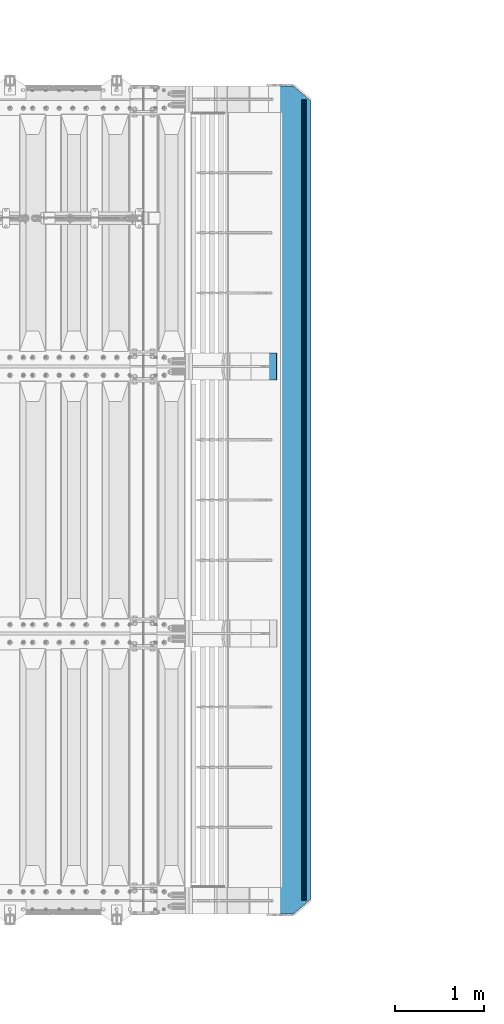
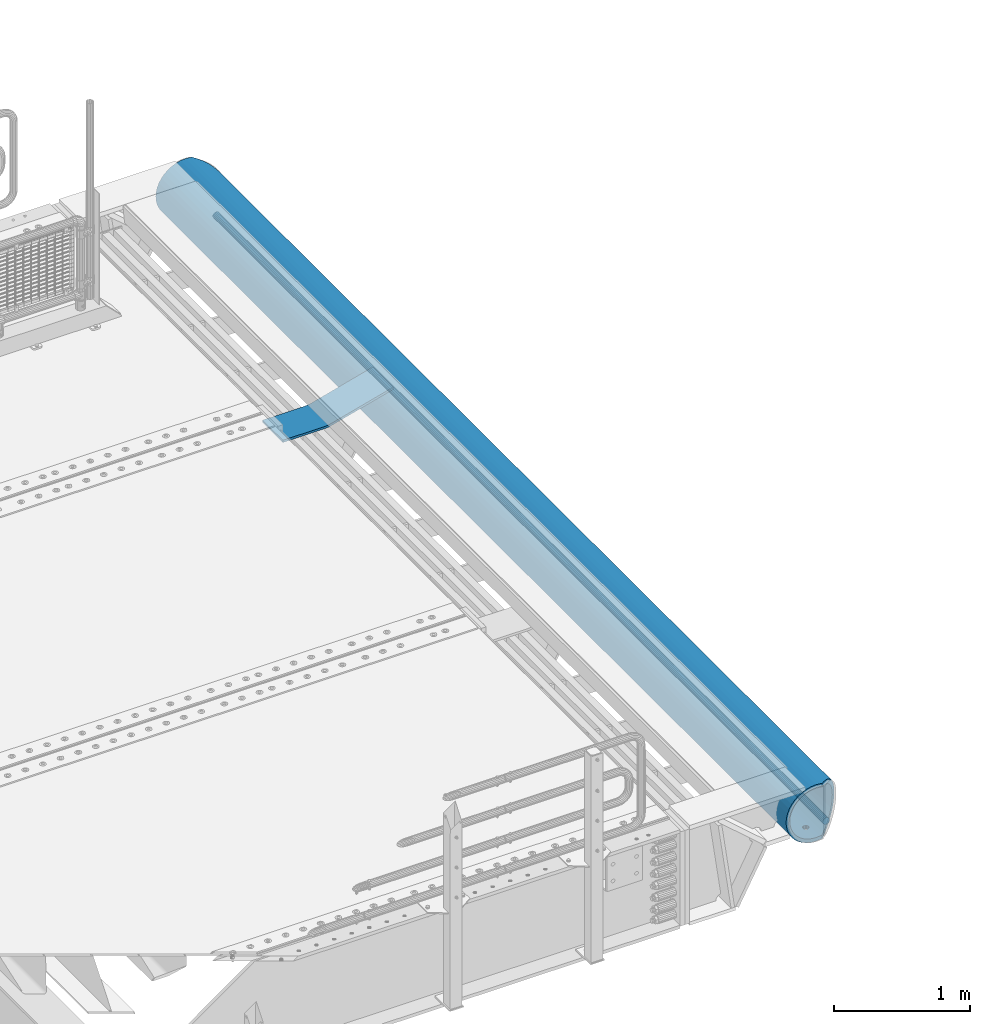
# One storey, part 133 of 247: 3 beams.
"""IFC2X3 building model written with IfcOpenShell, lengths in millimetres."""

from ifc_helpers import new_model, si_unit, frame, origin_with_axes, place, context, subcontext, project, spatial, faceted_brep, material, type_object, element, save


model = new_model("IFC2X3")

# Units and contexts
model_context = context("Model", 3, precision=1e-05, world=origin_with_axes())
body_context = subcontext(model_context, "Body", "Model", "MODEL_VIEW")
ifc_project = project(units=[si_unit("LENGTHUNIT", "METRE", prefix="MILLI"), si_unit("AREAUNIT", "SQUARE_METRE"), si_unit("VOLUMEUNIT", "CUBIC_METRE"), si_unit("MASSUNIT", "GRAM", prefix="KILO"), si_unit("TIMEUNIT", "SECOND"), si_unit("PLANEANGLEUNIT", "RADIAN"), si_unit("SOLIDANGLEUNIT", "STERADIAN"), si_unit("THERMODYNAMICTEMPERATUREUNIT", "DEGREE_CELSIUS"), si_unit("LUMINOUSINTENSITYUNIT", "LUMEN")], contexts=[model_context])

# Site, building, storey
site_placement = place(None, origin_with_axes())
site = spatial("IfcSite", under=ifc_project, at=site_placement, CompositionType="ELEMENT")
building_placement = place(site_placement, origin_with_axes())
building = spatial("IfcBuilding", under=site, at=building_placement, Name="Standard", CompositionType="ELEMENT")
storey_placement = place(building_placement, origin_with_axes())
storey = spatial("IfcBuildingStorey", under=building, at=storey_placement, Name="Undefined", CompositionType="ELEMENT", Elevation=0.0)

# Beams
ifc_material = material(Name="STEEL/S355N")
beam_type_1 = type_object("IfcBeamType", PredefinedType="NOTDEFINED")
beam_1_placement = place(storey_placement, frame((16896.9988298906, 6000.0, -169.999999999995), z_axis=(0.0, -0.999999999999548, -9.5100000000016e-07), x_axis=(1.0, 0.0, 0.0)))
element("IfcBeam", 1, at=beam_1_placement, inside=storey, type_object=beam_type_1, material=ifc_material, context=body_context, shape_type="Brep", body=[
    faceted_brep([(0.0, 10.0, -150.0), (0.0, 10.0, 150.0), (356.495387467741, 10.0, 150.0), (356.495387467749, 9.99999999999901, -150.0), (0.0, -10.0, 150.0), (0.0, -10.0, -150.0), (356.495387467741, -10.0, -150.0), (356.495387467741, -10.0, 150.0), (382.770279632416, 11.7334369044542, 150.0), (382.770279632416, 11.7334369044542, -150.0), (385.397768848896, -8.09321940509935, -150.0), (385.397768848896, -8.09321940509935, 150.0), (413.799145684919, -2.40593045895554, -150.0), (413.799145684919, -2.40593045895554, 150.0), (408.589713119687, 16.9036995827646, 150.0), (408.589713119891, 16.9036995827009, -150.0), (939.000000000015, 160.0, 150.0), (939.000000000015, 160.0, -150.0), (944.209432565229, 140.69036995827, 150.0), (944.209432565229, 140.69036995827, -150.0)], [[[0, 1, 2, 3]], [[4, 5, 6, 7]], [[5, 4, 1, 0]], [[3, 2, 8, 9]], [[7, 6, 10, 11]], [[10, 12, 13, 11]], [[8, 14, 15, 9]], [[15, 14, 16, 17]], [[14, 8, 2, 1, 4, 7, 11, 13, 18, 16]], [[13, 12, 19, 18]], [[12, 10, 6, 5, 0, 3, 9, 15, 17, 19]], [[18, 19, 17, 16]]]),
])
beam_type_2 = type_object("IfcBeamType", PredefinedType="NOTDEFINED")
beam_2_placement = place(storey_placement, frame((17972.9988298906, 9150.0, -254.000000000001), z_axis=(0.0, 0.0, 1.0), x_axis=(0.0, -0.999999999999548, -9.5100000000016e-07)))
element("IfcBeam", 2, at=beam_2_placement, inside=storey, type_object=beam_type_2, material=ifc_material, context=body_context, shape_type="Brep", body=[
    faceted_brep([(6132.32233047034, -17.6739734137809, -220.609028125962), (6132.32233047034, -17.6739734137809, -252.609028125962), (6126.90301168722, -9.56338969324497, -253.247344908112), (6126.90301168722, -9.56338969324497, -221.247344908112), (6140.43291419087, -23.0932921968997, -220.182518487904), (6140.43291419087, -23.0932921968997, -252.182518487904), (6150.0, -24.9963038841161, -220.032748220012), (6150.0, -24.9963038841161, -252.032748220013), (6159.56708580913, -23.0932921968997, -220.182518487904), (6159.56708580913, -23.0932921968997, -252.182518487904), (6167.67766952966, -17.6739734137809, -220.609028125962), (6167.67766952966, -17.6739734137809, -252.609028125962), (6173.09698831278, -9.56338969324497, -221.247344908112), (6173.09698831278, -9.56338969324497, -253.247344908112), (6175.0, 0.0, -222.0), (6175.0, 0.0, -254.0), (6173.09698831278, 9.57078192501285, -221.246763126856), (6173.09698831278, 9.57078192501285, -253.246763126856), (6167.67766952966, 17.6813656455488, -220.608446344706), (6167.67766952966, 17.6813656455488, -252.608446344706), (6159.56708580913, 23.1006844286676, -220.181936706648), (6159.56708580913, 23.1006844286676, -252.181936706647), (6150.0, 25.0036961158839, -220.032166438756), (6150.0, 25.0036961158839, -252.032166438756), (6140.43291419087, 23.1006844286676, -220.181936706648), (6140.43291419087, 23.1006844286676, -252.181936706647), (6132.32233047034, 17.6813656455488, -220.608446344706), (6132.32233047034, 17.6813656455488, -252.608446344706), (6126.90301168722, 9.57078192501285, -221.246763126856), (6126.90301168722, 9.57078192501285, -253.246763126856), (6125.0, 0.0, -222.0), (6125.0, 0.0, -254.0), (4632.32233047034, -17.6739734137773, -220.609028125962), (4632.32233047034, -17.6739734137773, -252.609028125962), (4626.90301168722, -9.56338969324133, -253.247344908112), (4626.90301168722, -9.56338969324133, -221.247344908112), (4640.43291419087, -23.0932921968961, -220.182518487904), (4640.43291419087, -23.0932921968961, -252.182518487903), (4650.0, -24.9963038841124, -220.032748220013), (4650.0, -24.9963038841124, -252.032748220012), (4659.56708580913, -23.0932921968961, -220.182518487904), (4659.56708580913, -23.0932921968961, -252.182518487903), (4667.67766952966, -17.6739734137773, -220.609028125962), (4667.67766952966, -17.6739734137773, -252.609028125962), (4673.09698831278, -9.56338969324133, -221.247344908112), (4673.09698831278, -9.56338969324133, -253.247344908112), (4675.0, 0.0, -222.0), (4675.0, 0.0, -254.0), (4673.09698831278, 9.57078192501649, -221.246763126856), (4673.09698831278, 9.57078192501649, -253.246763126855), (4667.67766952966, 17.6813656455524, -220.608446344706), (4667.67766952966, 17.6813656455524, -252.608446344705), (4659.56708580913, 23.1006844286712, -220.181936706647), (4659.56708580913, 23.1006844286712, -252.181936706647), (4650.0, 25.0036961158876, -220.032166438756), (4650.0, 25.0036961158876, -252.032166438756), (4640.43291419087, 23.1006844286712, -220.181936706647), (4640.43291419087, 23.1006844286712, -252.181936706647), (4632.32233047034, 17.6813656455524, -220.608446344706), (4632.32233047034, 17.6813656455524, -252.608446344705), (4626.90301168722, 9.57078192501649, -221.246763126856), (4626.90301168722, 9.57078192501649, -253.246763126855), (4625.0, 0.0, -222.0), (4625.0, 0.0, -254.0), (3132.32233047034, -17.6776695296612, -220.608737235334), (3132.32233047034, -17.6776695296612, -252.608737235334), (3126.90301168722, -9.56708580912527, -253.247054017484), (3126.90301168722, -9.56708580912527, -221.247054017484), (3140.43291419087, -23.09698831278, -220.182227597276), (3140.43291419087, -23.09698831278, -252.182227597276), (3150.0, -24.9999999999964, -220.032457329385), (3150.0, -24.9999999999964, -252.032457329385), (3159.56708580913, -23.09698831278, -220.182227597276), (3159.56708580913, -23.09698831278, -252.182227597276), (3167.67766952966, -17.6776695296612, -220.608737235334), (3167.67766952966, -17.6776695296612, -252.608737235334), (3173.09698831278, -9.56708580912527, -221.247054017484), (3173.09698831278, -9.56708580912527, -253.247054017484), (3175.0, 0.0, -222.0), (3175.0, 0.0, -254.0), (3173.09698831278, 9.56708580913255, -221.247054017484), (3173.09698831278, 9.56708580913255, -253.247054017483), (3167.67766952966, 17.6776695296685, -220.608737235334), (3167.67766952966, 17.6776695296685, -252.608737235333), (3159.56708580913, 23.0969883127873, -220.182227597276), (3159.56708580913, 23.0969883127873, -252.182227597275), (3150.0, 25.0000000000036, -220.032457329384), (3150.0, 25.0000000000036, -252.032457329384), (3140.43291419087, 23.0969883127873, -220.182227597276), (3140.43291419087, 23.0969883127873, -252.182227597275), (3132.32233047034, 17.6776695296685, -220.608737235334), (3132.32233047034, 17.6776695296685, -252.608737235333), (3126.90301168722, 9.56708580913255, -221.247054017484), (3126.90301168722, 9.56708580913255, -253.247054017483), (3125.0, 0.0, -222.0), (3125.0, 0.0, -254.0), (1632.32233047034, -17.6776695296612, -220.608737235334), (1632.32233047034, -17.6776695296612, -252.608737235334), (1626.90301168722, -9.56708580912527, -253.247054017484), (1626.90301168722, -9.56708580912527, -221.247054017484), (1640.43291419087, -23.09698831278, -220.182227597276), (1640.43291419087, -23.09698831278, -252.182227597276), (1650.0, -24.9999999999964, -220.032457329385), (1650.0, -24.9999999999964, -252.032457329385), (1659.56708580913, -23.09698831278, -220.182227597276), (1659.56708580913, -23.09698831278, -252.182227597276), (1667.67766952966, -17.6776695296612, -220.608737235334), (1667.67766952966, -17.6776695296612, -252.608737235334), (1673.09698831278, -9.56708580912527, -221.247054017484), (1673.09698831278, -9.56708580912527, -253.247054017484), (1675.0, 0.0, -222.0), (1675.0, 0.0, -254.0), (1673.09698831278, 9.56708580913255, -221.247054017484), (1673.09698831278, 9.56708580913255, -253.247054017484), (1667.67766952966, 17.6776695296685, -220.608737235334), (1667.67766952966, 17.6776695296685, -252.608737235334), (1659.56708580913, 23.0969883127873, -220.182227597276), (1659.56708580913, 23.0969883127873, -252.182227597275), (1650.0, 25.0000000000036, -220.032457329384), (1650.0, 25.0000000000036, -252.032457329384), (1640.43291419087, 23.0969883127873, -220.182227597276), (1640.43291419087, 23.0969883127873, -252.182227597275), (1632.32233047034, 17.6776695296685, -220.608737235334), (1632.32233047034, 17.6776695296685, -252.608737235334), (1626.90301168722, 9.56708580913255, -221.247054017484), (1626.90301168722, 9.56708580913255, -253.247054017484), (1625.0, 0.0, -222.0), (1625.0, 0.0, -254.0), (132.322330470337, -17.6776695296612, -220.608737235334), (132.322330470337, -17.6776695296612, -252.608737235334), (126.903011687218, -9.56708580912527, -253.247054017484), (126.903011687218, -9.56708580912527, -221.247054017484), (140.432914190873, -23.09698831278, -220.182227597276), (140.432914190873, -23.09698831278, -252.182227597276), (150.0, -24.9999999999964, -220.032457329385), (150.0, -24.9999999999964, -252.032457329385), (159.567085809127, -23.09698831278, -220.182227597276), (159.567085809127, -23.09698831278, -252.182227597276), (167.677669529663, -17.6776695296612, -220.608737235334), (167.677669529663, -17.6776695296612, -252.608737235334), (173.096988312782, -9.56708580912527, -221.247054017484), (173.096988312782, -9.56708580912527, -253.247054017484), (175.0, 0.0, -222.0), (175.0, 0.0, -254.0), (173.096988312782, 9.56708580913255, -221.247054017484), (173.096988312782, 9.56708580913255, -253.247054017484), (167.677669529663, 17.6776695296685, -220.608737235333), (167.677669529663, 17.6776695296685, -252.608737235334), (159.567085809127, 23.0969883127873, -220.182227597275), (159.567085809127, 23.0969883127873, -252.182227597275), (150.0, 25.0000000000036, -220.032457329384), (150.0, 25.0000000000036, -252.032457329384), (140.432914190873, 23.0969883127873, -220.182227597275), (140.432914190873, 23.0969883127873, -252.182227597275), (132.322330470337, 17.6776695296685, -220.608737235333), (132.322330470337, 17.6776695296685, -252.608737235334), (126.903011687218, 9.56708580913255, -221.247054017484), (126.903011687218, 9.56708580913255, -253.247054017484), (125.0, 0.0, -222.0), (125.0, 0.0, -254.0), (0.0, -34.7284512389306, -219.266811612121), (0.0, -68.6017727512371, -211.134546617524), (9300.0, -68.6017727512371, -211.134546617524), (9300.0, -34.7284512389306, -219.266811612121), (0.0, -100.785890942181, -197.803448369818), (9300.0, -100.785890942181, -197.803448369818), (0.0, -130.48832600893, -179.601772751238), (9300.0, -130.48832600893, -179.601772751238), (0.0, -156.977705423415, -156.977705423414), (9300.0, -156.977705423415, -156.977705423414), (0.0, -179.601772751237, -130.488326008929), (9300.0, -179.601772751237, -130.488326008929), (0.0, -197.803448369817, -100.785890942179), (9300.0, -197.803448369817, -100.785890942179), (0.0, -211.134546617523, -68.6017727512383), (9300.0, -211.134546617523, -68.6017727512383), (0.0, -219.26681161212, -34.7284512389313), (9300.0, -219.26681161212, -34.7284512389313), (0.0, -222.0, 0.0), (9300.0, -222.0, 0.0), (0.0, -219.26681161212, 34.7284512389313), (9300.0, -219.26681161212, 34.7284512389313), (0.0, -211.134546617523, 68.6017727512384), (9300.0, -211.134546617523, 68.6017727512384), (0.0, -197.803448369817, 100.785890942179), (9300.0, -197.803448369817, 100.785890942179), (0.0, -179.601772751237, 130.488326008929), (9300.0, -179.601772751237, 130.488326008929), (0.0, -156.977705423415, 156.977705423414), (9300.0, -156.977705423415, 156.977705423414), (0.0, -130.48832600893, 179.601772751238), (9300.0, -130.48832600893, 179.601772751238), (0.0, -100.785890942181, 197.803448369818), (9300.0, -100.785890942181, 197.803448369818), (0.0, -68.6017727512371, 211.134546617524), (9300.0, -68.6017727512371, 211.134546617524), (0.0, -34.7284512389306, 219.266811612121), (9300.0, -34.7284512389306, 219.266811612121), (0.0, 0.0, 222.0), (9300.0, 0.0, 222.0), (0.0, 34.7284512389306, 219.266811612121), (9300.0, 34.7284512389306, 219.266811612121), (9287.5916350975, 68.6017727512371, 211.134546617524), (9300.0, 54.0036961158876, 214.639234741095), (0.0, 54.0000000000036, 214.64012210001), (12.411506742721, 68.6017727512371, 211.134546617524), (9260.23513515892, 100.785890942181, 197.803448369818), (39.7680069938197, 100.785890942181, 197.803448369818), (9234.98806583553, 130.48832600893, 179.601772751238), (65.015076605634, 130.48832600893, 179.601772751238), (9212.47209376427, 156.977705423415, 156.977705423414), (87.5310489341118, 156.977705423415, 156.977705423414), (9193.24163690377, 179.601772751237, 130.488326008929), (106.761506014294, 179.601772751237, 130.488326008929), (9177.77021292417, 197.803448369817, 100.785890942179), (122.232930170643, 197.803448369817, 100.785890942179), (9166.43877963055, 211.134546617523, 68.6017727512383), (133.564363593709, 211.134546617523, 68.6017727512383), (9159.52635451748, 219.26681161212, 34.7284512389312), (140.476788785749, 219.26681161212, 34.7284512389312), (9157.20314443226, 222.0, -2.8421709430404e-14), (142.799998897508, 222.0, -2.8421709430404e-14), (9159.52635451748, 219.26681161212, -34.7284512389313), (140.476788785749, 219.26681161212, -34.7284512389313), (9166.43877963055, 211.134546617523, -68.6017727512383), (133.564363593709, 211.134546617523, -68.6017727512383), (9177.77021292417, 197.803448369817, -100.785890942179), (122.232930170643, 197.803448369817, -100.785890942179), (9193.24163690377, 179.601772751237, -130.488326008929), (106.761506014294, 179.601772751237, -130.488326008929), (9212.47209376427, 156.977705423415, -156.977705423414), (87.5310489341118, 156.977705423415, -156.977705423414), (9234.98806583553, 130.48832600893, -179.601772751238), (65.015076605634, 130.48832600893, -179.601772751238), (9260.23513515892, 100.785890942181, -197.803448369818), (39.7680069938197, 100.785890942181, -197.803448369818), (9287.5916350975, 68.6017727512371, -211.134546617524), (12.411506742721, 68.6017727512371, -211.134546617524), (0.0, 34.7284512389306, -219.266811612121), (9300.0, 34.7284512389306, -219.266811612121), (9300.0, 54.0036961158876, -214.639234741095), (0.0, 54.0000000000036, -214.64012210001), (9140.57004288257, 241.56835513897, -78.4903165712366), (9153.53483593022, 226.315657143845, -115.313586933845), (146.468307441455, 226.315657143845, -115.313586933845), (159.433100637219, 241.56835513897, -78.4903165712366), (9171.23637507805, 205.490316571235, -149.297454082288), (128.766768091398, 205.490316571235, -149.297454082288), (9193.2387896842, 179.605122421384, -179.605122421383), (106.764353233899, 179.605122421384, -179.605122421383), (9219.00030727925, 149.297454082287, -205.490316571237), (81.0028353445578, 149.297454082287, -205.490316571237), (9247.88659380242, 115.313586933844, -226.315657143845), (52.1165484913945, 115.313586933844, -226.315657143845), (9279.18637301142, 78.4903165712349, -241.568355138969), (20.8167689248257, 78.4903165712349, -241.568355138969), (9300.0, 54.0036961158876, -247.447072591955), (9300.0, 39.7343541202172, -250.872838511165), (0.0, 39.7343541202172, -250.872838511165), (0.0, 54.0000000000036, -247.447959950869), (0.0, 0.0, -222.0), (0.0, 0.0, -254.0), (0.0, -39.7343541202172, -250.872838511165), (0.0, -78.4903165712349, -241.568355138969), (0.0, -115.313586933844, -226.315657143845), (0.0, -149.297454082287, -205.490316571237), (0.0, -179.605122421384, -179.605122421383), (0.0, -205.490316571235, -149.297454082288), (0.0, -226.315657143845, -115.313586933845), (0.0, -241.56835513897, -78.4903165712367), (0.0, -250.872838511164, -39.7343541202187), (0.0, -254.0, 0.0), (0.0, -250.872838511164, 39.7343541202187), (0.0, -241.56835513897, 78.4903165712366), (0.0, -226.315657143845, 115.313586933845), (0.0, -205.490316571235, 149.297454082288), (0.0, -179.605122421384, 179.605122421383), (0.0, -149.297454082287, 205.490316571237), (0.0, -115.313586933844, 226.315657143845), (0.0, -78.4903165712349, 241.568355138969), (0.0, -39.7343541202172, 250.872838511165), (0.0, 0.0, 254.0), (0.0, 39.7343541202172, 250.872838511165), (0.0, 54.0000000000036, 247.447959950869), (9300.0, -39.7343541202172, -250.872838511165), (9300.0, -78.4903165712349, -241.568355138969), (9300.0, -115.313586933844, -226.315657143845), (9300.0, -149.297454082287, -205.490316571237), (9300.0, -179.605122421384, -179.605122421383), (9300.0, -205.490316571235, -149.297454082288), (9300.0, -226.315657143845, -115.313586933845), (9300.0, -241.56835513897, -78.4903165712367), (9300.0, -250.872838511164, -39.7343541202187), (9300.0, -254.0, 0.0), (9300.0, -250.872838511164, 39.7343541202187), (9300.0, -241.56835513897, 78.4903165712366), (9300.0, -226.315657143845, 115.313586933845), (9300.0, -205.490316571235, 149.297454082288), (9300.0, -179.605122421384, 179.605122421383), (9300.0, -149.297454082287, 205.490316571237), (9300.0, -115.313586933844, 226.315657143845), (9300.0, -78.4903165712349, 241.568355138969), (9300.0, -39.7343541202172, 250.872838511165), (9300.0, 0.0, 254.0), (9300.0, 39.7343541202172, 250.872838511165), (9300.0, 54.0036961158876, 247.447072591955), (9279.18637301142, 78.4903165712349, 241.568355138969), (20.8167689248257, 78.4903165712349, 241.568355138969), (9247.88659380242, 115.313586933844, 226.315657143845), (52.1165484913945, 115.313586933844, 226.315657143845), (9219.00030727925, 149.297454082287, 205.490316571237), (81.0028353445578, 149.297454082287, 205.490316571237), (9193.2387896842, 179.605122421384, 179.605122421383), (106.764353233899, 179.605122421384, 179.605122421383), (9171.23637507805, 205.490316571235, 149.297454082288), (128.766768091398, 205.490316571235, 149.297454082288), (9153.53483593022, 226.315657143845, 115.313586933845), (146.468307441455, 226.315657143845, 115.313586933845), (9140.57004288257, 241.56835513897, 78.4903165712367), (159.433100637219, 241.56835513897, 78.4903165712367), (9129.99999983224, 254.003700142126, 0.0), (9132.66123216761, 250.872838511164, -39.7343541202186), (167.341911442523, 250.872838511164, -39.7343541202186), (170.000001295226, 254.000003067897, 5.6843418860808e-14), (9132.66123216761, 250.872838511164, 39.7343541202187), (167.341911442523, 250.872838511164, 39.7343541202187), (9300.0, 0.0, -254.0), (9300.0, 0.0, -222.0), (7675.0, 0.0, -222.0), (7673.09698831278, -9.56338969324497, -221.247344908112), (7667.67766952966, -17.6739734137809, -220.609028125962), (7659.56708580913, -23.0932921968997, -220.182518487904), (7650.0, -24.9963038841161, -220.032748220013), (7640.43291419087, -23.0932921968997, -220.182518487904), (7632.32233047034, -17.6739734137809, -220.609028125962), (7626.90301168722, -9.56338969324497, -221.247344908112), (7625.0, 0.0, -222.0), (9175.0, 0.0, -222.0), (9173.09698831278, -9.56338969324861, -221.247344908111), (9167.67766952966, -17.6739734137846, -220.609028125961), (9159.56708580913, -23.0932921969033, -220.182518487903), (9150.0, -24.9963038841197, -220.032748220012), (9140.43291419087, -23.0932921969033, -220.182518487903), (9132.32233047034, -17.6739734137846, -220.609028125961), (9126.90301168722, -9.56338969324861, -221.247344908111), (9125.0, 0.0, -222.0), (9167.67766952966, 17.6813656455452, -220.608446344706), (9173.09698831278, 9.57078192500921, -221.246763126856), (7626.90301168722, 9.57078192501285, -221.246763126856), (7632.32233047034, 17.6813656455488, -220.608446344706), (7640.43291419087, 23.1006844286676, -220.181936706648), (7650.0, 25.0036961158839, -220.032166438757), (7659.56708580913, 23.1006844286676, -220.181936706648), (7667.67766952966, 17.6813656455488, -220.608446344706), (7673.09698831278, 9.57078192501285, -221.246763126856), (9126.90301168722, 9.57078192500921, -221.246763126856), (9132.32233047034, 17.6813656455452, -220.608446344706), (9140.43291419087, 23.100684428664, -220.181936706648), (9150.0, 25.0036961158803, -220.032166438757), (9159.56708580913, 23.100684428664, -220.181936706648), (7673.09698831278, 9.57078192501285, -253.246763126855), (7675.0, 0.0, -254.0), (7667.67766952966, 17.6813656455488, -252.608446344705), (7659.56708580913, 23.1006844286676, -252.181936706647), (7650.0, 25.0036961158839, -252.032166438756), (7640.43291419087, 23.1006844286676, -252.181936706647), (7632.32233047034, 17.6813656455488, -252.608446344705), (7626.90301168722, 9.57078192501285, -253.246763126855), (7625.0, 0.0, -254.0), (7626.90301168722, -9.56338969324497, -253.247344908111), (7632.32233047034, -17.6739734137809, -252.609028125961), (7640.43291419087, -23.0932921968997, -252.182518487903), (7650.0, -24.9963038841161, -252.032748220012), (7659.56708580913, -23.0932921968997, -252.182518487903), (7667.67766952966, -17.6739734137809, -252.609028125961), (7673.09698831278, -9.56338969324497, -253.247344908111), (9132.32233047034, -17.6739734137846, -252.609028125961), (9140.43291419087, -23.0932921969033, -252.182518487903), (9150.0, -24.9963038841197, -252.032748220012), (9159.56708580913, -23.0932921969033, -252.182518487903), (9167.67766952966, -17.6739734137846, -252.609028125961), (9173.09698831278, -9.56338969324861, -253.247344908111), (9175.0, 0.0, -254.0), (9125.0, 0.0, -254.0), (9126.90301168722, -9.56338969324861, -253.247344908111), (9132.32233047034, 17.6813656455452, -252.608446344706), (9126.90301168722, 9.57078192500921, -253.246763126856), (9173.09698831278, 9.57078192500921, -253.246763126856), (9167.67766952966, 17.6813656455452, -252.608446344706), (9159.56708580913, 23.100684428664, -252.181936706648), (9150.0, 25.0036961158803, -252.032166438757), (9140.43291419087, 23.100684428664, -252.181936706648)], [[[0, 1, 2, 3]], [[4, 5, 1, 0]], [[6, 7, 5, 4]], [[8, 9, 7, 6]], [[10, 11, 9, 8]], [[12, 13, 11, 10]], [[14, 15, 13, 12]], [[16, 17, 15, 14]], [[18, 19, 17, 16]], [[20, 21, 19, 18]], [[22, 23, 21, 20]], [[24, 25, 23, 22]], [[26, 27, 25, 24]], [[28, 29, 27, 26]], [[30, 31, 29, 28]], [[3, 2, 31, 30]], [[32, 33, 34, 35]], [[36, 37, 33, 32]], [[38, 39, 37, 36]], [[40, 41, 39, 38]], [[42, 43, 41, 40]], [[44, 45, 43, 42]], [[46, 47, 45, 44]], [[48, 49, 47, 46]], [[50, 51, 49, 48]], [[52, 53, 51, 50]], [[54, 55, 53, 52]], [[56, 57, 55, 54]], [[58, 59, 57, 56]], [[60, 61, 59, 58]], [[62, 63, 61, 60]], [[35, 34, 63, 62]], [[64, 65, 66, 67]], [[68, 69, 65, 64]], [[70, 71, 69, 68]], [[72, 73, 71, 70]], [[74, 75, 73, 72]], [[76, 77, 75, 74]], [[78, 79, 77, 76]], [[80, 81, 79, 78]], [[82, 83, 81, 80]], [[84, 85, 83, 82]], [[86, 87, 85, 84]], [[88, 89, 87, 86]], [[90, 91, 89, 88]], [[92, 93, 91, 90]], [[94, 95, 93, 92]], [[67, 66, 95, 94]], [[96, 97, 98, 99]], [[100, 101, 97, 96]], [[102, 103, 101, 100]], [[104, 105, 103, 102]], [[106, 107, 105, 104]], [[108, 109, 107, 106]], [[110, 111, 109, 108]], [[112, 113, 111, 110]], [[114, 115, 113, 112]], [[116, 117, 115, 114]], [[118, 119, 117, 116]], [[120, 121, 119, 118]], [[122, 123, 121, 120]], [[124, 125, 123, 122]], [[126, 127, 125, 124]], [[99, 98, 127, 126]], [[128, 129, 130, 131]], [[132, 133, 129, 128]], [[134, 135, 133, 132]], [[136, 137, 135, 134]], [[138, 139, 137, 136]], [[140, 141, 139, 138]], [[142, 143, 141, 140]], [[144, 145, 143, 142]], [[146, 147, 145, 144]], [[148, 149, 147, 146]], [[150, 151, 149, 148]], [[152, 153, 151, 150]], [[154, 155, 153, 152]], [[156, 157, 155, 154]], [[158, 159, 157, 156]], [[131, 130, 159, 158]], [[160, 161, 162, 163]], [[161, 164, 165, 162]], [[164, 166, 167, 165]], [[166, 168, 169, 167]], [[168, 170, 171, 169]], [[170, 172, 173, 171]], [[172, 174, 175, 173]], [[174, 176, 177, 175]], [[176, 178, 179, 177]], [[178, 180, 181, 179]], [[180, 182, 183, 181]], [[182, 184, 185, 183]], [[184, 186, 187, 185]], [[186, 188, 189, 187]], [[188, 190, 191, 189]], [[190, 192, 193, 191]], [[192, 194, 195, 193]], [[194, 196, 197, 195]], [[196, 198, 199, 197]], [[198, 200, 201, 199]], [[202, 203, 201, 200, 204, 205]], [[206, 202, 205, 207]], [[208, 206, 207, 209]], [[210, 208, 209, 211]], [[212, 210, 211, 213]], [[214, 212, 213, 215]], [[216, 214, 215, 217]], [[218, 216, 217, 219]], [[220, 218, 219, 221]], [[222, 220, 221, 223]], [[224, 222, 223, 225]], [[226, 224, 225, 227]], [[228, 226, 227, 229]], [[230, 228, 229, 231]], [[232, 230, 231, 233]], [[234, 232, 233, 235]], [[236, 234, 235, 237]], [[238, 239, 240, 236, 237, 241]], [[242, 243, 244, 245]], [[243, 246, 247, 244]], [[246, 248, 249, 247]], [[248, 250, 251, 249]], [[250, 252, 253, 251]], [[252, 254, 255, 253]], [[254, 256, 257, 258, 259, 255]], [[200, 198, 196, 194, 192, 190, 188, 186, 184, 182, 180, 178, 176, 174, 172, 170, 168, 166, 164, 161, 160, 260, 238, 241, 259, 258, 261, 262, 263, 264, 265, 266, 267, 268, 269, 270, 271, 272, 273, 274, 275, 276, 277, 278, 279, 280, 281, 282, 283, 204]], [[263, 262, 284, 285]], [[264, 263, 285, 286]], [[265, 264, 286, 287]], [[266, 265, 287, 288]], [[267, 266, 288, 289]], [[268, 267, 289, 290]], [[269, 268, 290, 291]], [[270, 269, 291, 292]], [[271, 270, 292, 293]], [[272, 271, 293, 294]], [[273, 272, 294, 295]], [[274, 273, 295, 296]], [[275, 274, 296, 297]], [[276, 275, 297, 298]], [[277, 276, 298, 299]], [[278, 277, 299, 300]], [[279, 278, 300, 301]], [[280, 279, 301, 302]], [[281, 280, 302, 303]], [[282, 281, 303, 304]], [[282, 304, 305, 306, 307, 283]], [[306, 308, 309, 307]], [[308, 310, 311, 309]], [[310, 312, 313, 311]], [[312, 314, 315, 313]], [[314, 316, 317, 315]], [[316, 318, 319, 317]], [[320, 321, 322, 323]], [[324, 320, 323, 325]], [[318, 324, 325, 319]], [[323, 322, 245, 244, 247, 249, 251, 253, 255, 259, 241, 237, 235, 233, 231, 229, 227, 225, 223, 221, 219, 217, 215, 213, 211, 209, 207, 205, 204, 283, 307, 309, 311, 313, 315, 317, 319, 325]], [[321, 242, 245, 322]], [[320, 324, 318, 316, 314, 312, 310, 308, 306, 305, 203, 202, 206, 208, 210, 212, 214, 216, 218, 220, 222, 224, 226, 228, 230, 232, 234, 236, 240, 256, 254, 252, 250, 248, 246, 243, 242, 321]], [[304, 303, 302, 301, 300, 299, 298, 297, 296, 295, 294, 293, 292, 291, 290, 289, 288, 287, 286, 285, 284, 326, 257, 256, 240, 239, 327, 163, 162, 165, 167, 169, 171, 173, 175, 177, 179, 181, 183, 185, 187, 189, 191, 193, 195, 197, 199, 201, 203, 305]], [[328, 329, 330, 331, 332, 333, 334, 335, 336, 14, 12, 10, 8, 6, 4, 0, 3, 30, 46, 44, 42, 40, 38, 36, 32, 35, 62, 78, 76, 74, 72, 70, 68, 64, 67, 94, 110, 108, 106, 104, 102, 100, 96, 99, 126, 142, 140, 138, 136, 134, 132, 128, 131, 158, 260, 160, 163, 327, 337, 338, 339, 340, 341, 342, 343, 344, 345]], [[346, 347, 337, 327, 239, 238, 260, 158, 156, 154, 152, 150, 148, 146, 144, 142, 126, 124, 122, 120, 118, 116, 114, 112, 110, 94, 92, 90, 88, 86, 84, 82, 80, 78, 62, 60, 58, 56, 54, 52, 50, 48, 46, 30, 28, 26, 24, 22, 20, 18, 16, 14, 336, 348, 349, 350, 351, 352, 353, 354, 328, 345, 355, 356, 357, 358, 359]], [[354, 360, 361, 328]], [[353, 362, 360, 354]], [[352, 363, 362, 353]], [[351, 364, 363, 352]], [[350, 365, 364, 351]], [[349, 366, 365, 350]], [[348, 367, 366, 349]], [[336, 368, 367, 348]], [[335, 369, 368, 336]], [[334, 370, 369, 335]], [[333, 371, 370, 334]], [[332, 372, 371, 333]], [[331, 373, 372, 332]], [[330, 374, 373, 331]], [[329, 375, 374, 330]], [[328, 361, 375, 329]], [[376, 377, 378, 379, 380, 381, 382, 326, 284, 262, 261, 159, 130, 129, 133, 135, 137, 139, 141, 143, 127, 98, 97, 101, 103, 105, 107, 109, 111, 95, 66, 65, 69, 71, 73, 75, 77, 79, 63, 34, 33, 37, 39, 41, 43, 45, 47, 31, 2, 1, 5, 7, 9, 11, 13, 15, 368, 369, 370, 371, 372, 373, 374, 375, 361, 383, 384]], [[385, 386, 383, 361, 360, 362, 363, 364, 365, 366, 367, 368, 15, 17, 19, 21, 23, 25, 27, 29, 31, 47, 49, 51, 53, 55, 57, 59, 61, 63, 79, 81, 83, 85, 87, 89, 91, 93, 95, 111, 113, 115, 117, 119, 121, 123, 125, 127, 143, 145, 147, 149, 151, 153, 155, 157, 159, 261, 258, 257, 326, 382, 387, 388, 389, 390, 391]], [[358, 390, 389, 359]], [[357, 391, 390, 358]], [[356, 385, 391, 357]], [[355, 386, 385, 356]], [[345, 383, 386, 355]], [[344, 384, 383, 345]], [[343, 376, 384, 344]], [[342, 377, 376, 343]], [[341, 378, 377, 342]], [[340, 379, 378, 341]], [[339, 380, 379, 340]], [[338, 381, 380, 339]], [[337, 382, 381, 338]], [[347, 387, 382, 337]], [[346, 388, 387, 347]], [[359, 389, 388, 346]]]),
])
beam_type_3 = type_object("IfcBeamType", Name="D60", PredefinedType="NOTDEFINED")
beam_3_placement = place(storey_placement, frame((18146.7525260065, 8.71599089198909e-15, -478.0), z_axis=(0.0, 0.0, 1.0), x_axis=(0.0, 1.0, 0.0)))
element("IfcBeam", 3, at=beam_3_placement, inside=storey, type_object=beam_type_3, material=ifc_material, ObjectType="D60", context=body_context, shape_type="Brep", body=[
    faceted_brep([(-8.67361737988404e-19, -30.0, 0.0), (-8.67361737988404e-19, -27.7163859753382, -11.4805029709527), (9000.00000000076, -27.7163859753382, -11.4805029709527), (9000.00000000076, -30.0, 0.0), (-2.60208521396521e-18, -21.2132034356, -21.2132034355964), (9000.00000000076, -21.2132034356, -21.2132034355964), (-2.60208521396521e-18, -11.4805029709569, -27.7163859753386), (9000.00000000076, -11.4805029709569, -27.7163859753386), (-1.73472347597681e-18, -3.63797880709171e-12, -30.0), (9000.00000000076, -3.63797880709171e-12, -30.0), (-8.67361737988404e-19, 11.4805029709532, -27.7163859753386), (9000.00000000076, 11.4805029709532, -27.7163859753386), (-8.67361737988404e-19, 21.2132034355964, -21.2132034355964), (9000.00000000076, 21.2132034355964, -21.2132034355964), (-2.60208521396521e-18, 27.7163859753346, -11.4805029709527), (9000.00000000076, 27.7163859753346, -11.4805029709527), (-1.73472347597681e-18, 29.9999999999964, 0.0), (9000.00000000076, 29.9999999999964, 0.0), (-2.60208521396521e-18, 27.7163859753346, 11.4805029709527), (9000.00000000076, 27.7163859753346, 11.4805029709527), (-8.67361737988404e-19, 21.2132034355964, 21.2132034355964), (9000.00000000076, 21.2132034355964, 21.2132034355964), (-8.67361737988404e-19, 11.4805029709532, 27.7163859753386), (9000.00000000076, 11.4805029709532, 27.7163859753386), (-1.73472347597681e-18, -3.63797880709171e-12, 30.0), (9000.00000000076, -3.63797880709171e-12, 30.0), (-2.60208521396521e-18, -11.4805029709569, 27.7163859753386), (9000.00000000076, -11.4805029709569, 27.7163859753386), (-2.60208521396521e-18, -21.2132034356, 21.2132034355964), (9000.00000000076, -21.2132034356, 21.2132034355964), (-8.67361737988404e-19, -27.7163859753382, 11.4805029709527), (9000.00000000076, -27.7163859753382, 11.4805029709527)], [[[0, 1, 2, 3]], [[1, 4, 5, 2]], [[4, 6, 7, 5]], [[6, 8, 9, 7]], [[8, 10, 11, 9]], [[10, 12, 13, 11]], [[12, 14, 15, 13]], [[14, 16, 17, 15]], [[16, 18, 19, 17]], [[18, 20, 21, 19]], [[20, 22, 23, 21]], [[22, 24, 25, 23]], [[24, 26, 27, 25]], [[26, 28, 29, 27]], [[28, 30, 31, 29]], [[30, 0, 3, 31]], [[5, 7, 9, 11, 13, 15, 17, 19, 21, 23, 25, 27, 29, 31, 3, 2]], [[30, 28, 26, 24, 22, 20, 18, 16, 14, 12, 10, 8, 6, 4, 1, 0]]]),
])

save(model, "model.ifc")
